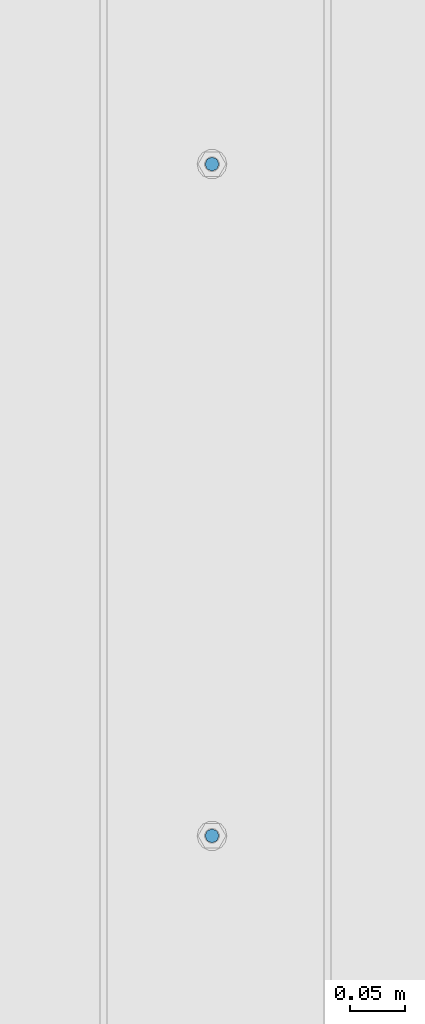
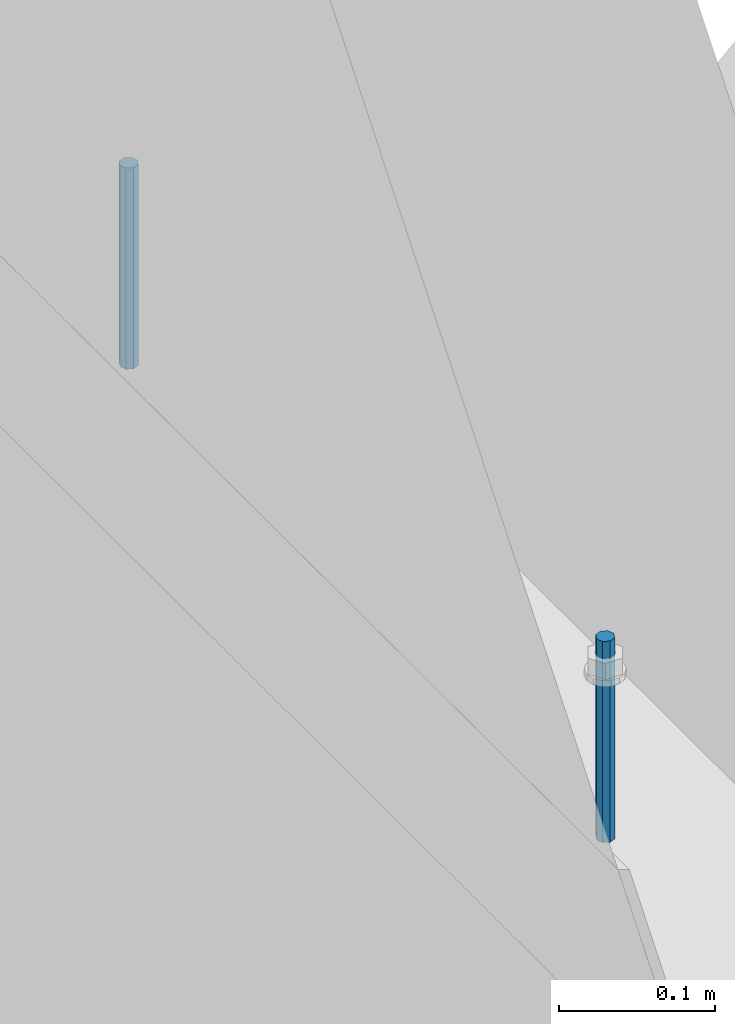
# One storey, part 430 of 1179: 2 columns, 1 element without a shape of its own.
"""IFC2X3 building model written with IfcOpenShell, lengths in millimetres."""

from ifc_helpers import new_model, si_unit, frame, origin_with_axes, place, context, subcontext, project, spatial, faceted_brep, material, type_object, element, aggregate, save


model = new_model("IFC2X3")

# Units and contexts
model_context = context("Model", 3, precision=1e-05, world=origin_with_axes())
body_context = subcontext(model_context, "Body", "Model", "MODEL_VIEW")
ifc_project = project(units=[si_unit("LENGTHUNIT", "METRE", prefix="MILLI"), si_unit("AREAUNIT", "SQUARE_METRE"), si_unit("VOLUMEUNIT", "CUBIC_METRE"), si_unit("MASSUNIT", "GRAM", prefix="KILO"), si_unit("TIMEUNIT", "SECOND"), si_unit("PLANEANGLEUNIT", "RADIAN"), si_unit("SOLIDANGLEUNIT", "STERADIAN"), si_unit("THERMODYNAMICTEMPERATUREUNIT", "DEGREE_CELSIUS"), si_unit("LUMINOUSINTENSITYUNIT", "LUMEN")], contexts=[model_context])

# Site, building, storey
site_placement = place(None, origin_with_axes())
site = spatial("IfcSite", under=ifc_project, at=site_placement, CompositionType="ELEMENT")
building_placement = place(site_placement, origin_with_axes())
building = spatial("IfcBuilding", under=site, at=building_placement, Name="Undefined", CompositionType="ELEMENT")
storey_placement = place(building_placement, origin_with_axes())
storey = spatial("IfcBuildingStorey", under=building, at=storey_placement, Name="Undefined", CompositionType="ELEMENT", Elevation=0.0)

# Assembly, columns
assembly_placement = place(storey_placement, origin_with_axes())
assembly = element("IfcElementAssembly", 1, at=assembly_placement, inside=storey, Name="BEAM", AssemblyPlace="NOTDEFINED", PredefinedType="RIGID_FRAME")
ifc_material = material(Name="STEEL/A307")
column_type = type_object("IfcColumnType", PredefinedType="NOTDEFINED")
column_1_placement = place(assembly_placement, frame((101.599999999999, 31635.70025, 4108.45), z_axis=(0.0, 1.0, 0.0), x_axis=(0.0, 0.0, 1.0)))
column_1 = element("IfcColumn", 2, at=column_1_placement, type_object=column_type, material=ifc_material, Name="THREADED ROD", context=body_context, shape_type="Brep", body=[
    faceted_brep([(0.0, -6.34999999999854, 0.0), (0.0, -4.49012806053361, -4.49012806053452), (157.162499999999, -4.49012806053361, -4.49012806053361), (157.162499999999, -6.34999999999854, 0.0), (0.0, 0.0, -6.34999999999991), (157.162499999999, 0.0, -6.34999999999854), (0.0, 4.49012806053361, -4.49012806053452), (157.162499999999, 4.49012806053361, -4.49012806053361), (0.0, 6.34999999999854, 0.0), (157.162499999999, 6.34999999999854, 0.0), (0.0, 4.49012806053361, 4.49012806053452), (157.162499999999, 4.49012806053361, 4.49012806053361), (0.0, 0.0, 6.34999999999991), (157.162499999999, 0.0, 6.34999999999854), (0.0, -4.49012806053361, 4.49012806053452), (157.162499999999, -4.49012806053361, 4.49012806053361)], [[[0, 1, 2, 3]], [[1, 4, 5, 2]], [[4, 6, 7, 5]], [[6, 8, 9, 7]], [[8, 10, 11, 9]], [[10, 12, 13, 11]], [[12, 14, 15, 13]], [[14, 0, 3, 15]], [[5, 7, 9, 11, 13, 15, 3, 2]], [[14, 12, 10, 8, 6, 4, 1, 0]]]),
])
column_2_placement = place(assembly_placement, frame((101.599999999999, 31026.10025, 4108.45), z_axis=(0.0, 1.0, 0.0), x_axis=(0.0, 0.0, 1.0)))
column_2 = element("IfcColumn", 3, at=column_2_placement, type_object=column_type, material=ifc_material, Name="THREADED ROD", context=body_context, shape_type="Brep", body=[
    faceted_brep([(0.0, -6.34999999999854, 0.0), (0.0, -4.49012806053361, -4.49012806053452), (157.162499999999, -4.49012806053361, -4.49012806053361), (157.162499999999, -6.34999999999854, 0.0), (0.0, 0.0, -6.34999999999991), (157.162499999999, 0.0, -6.34999999999854), (0.0, 4.49012806053361, -4.49012806053452), (157.162499999999, 4.49012806053361, -4.49012806053361), (0.0, 6.34999999999854, 0.0), (157.162499999999, 6.34999999999854, 0.0), (0.0, 4.49012806053361, 4.49012806053452), (157.162499999999, 4.49012806053361, 4.49012806053361), (0.0, 0.0, 6.34999999999991), (157.162499999999, 0.0, 6.34999999999854), (0.0, -4.49012806053361, 4.49012806053452), (157.162499999999, -4.49012806053361, 4.49012806053361)], [[[0, 1, 2, 3]], [[1, 4, 5, 2]], [[4, 6, 7, 5]], [[6, 8, 9, 7]], [[8, 10, 11, 9]], [[10, 12, 13, 11]], [[12, 14, 15, 13]], [[14, 0, 3, 15]], [[5, 7, 9, 11, 13, 15, 3, 2]], [[14, 12, 10, 8, 6, 4, 1, 0]]]),
])
aggregate(assembly, [column_1, column_2])

save(model, "model.ifc")
